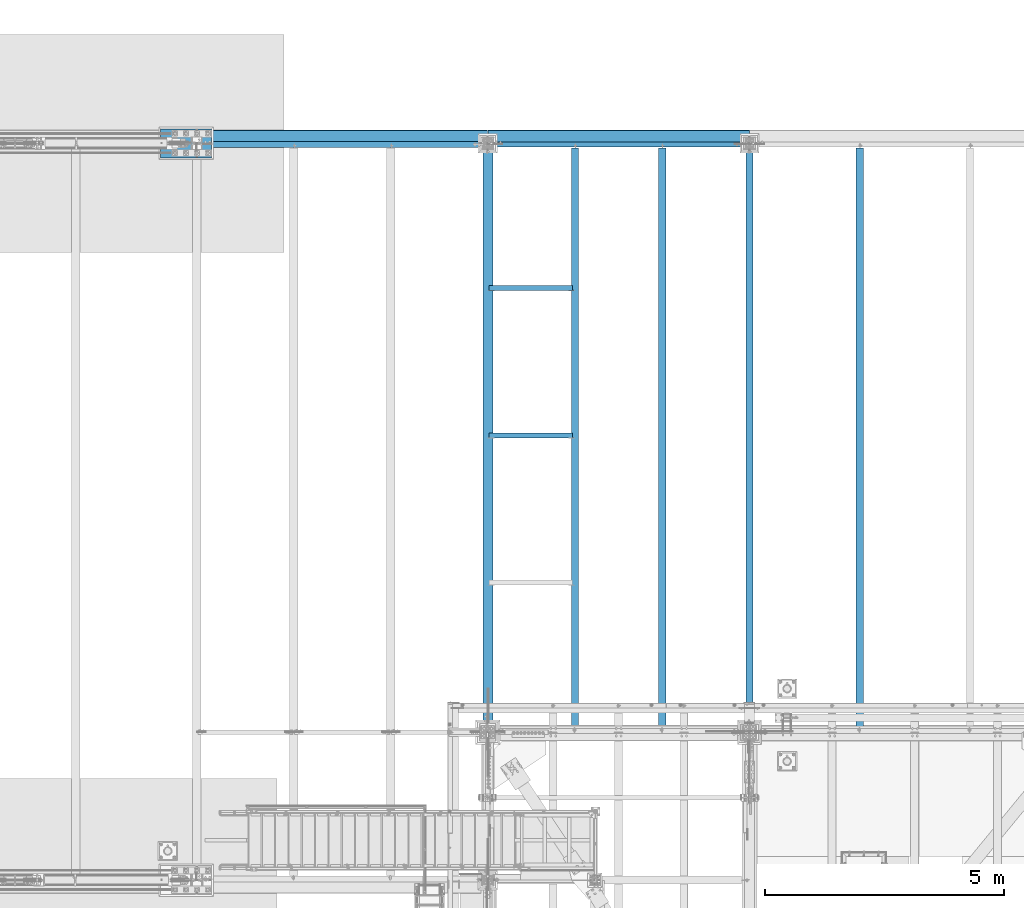
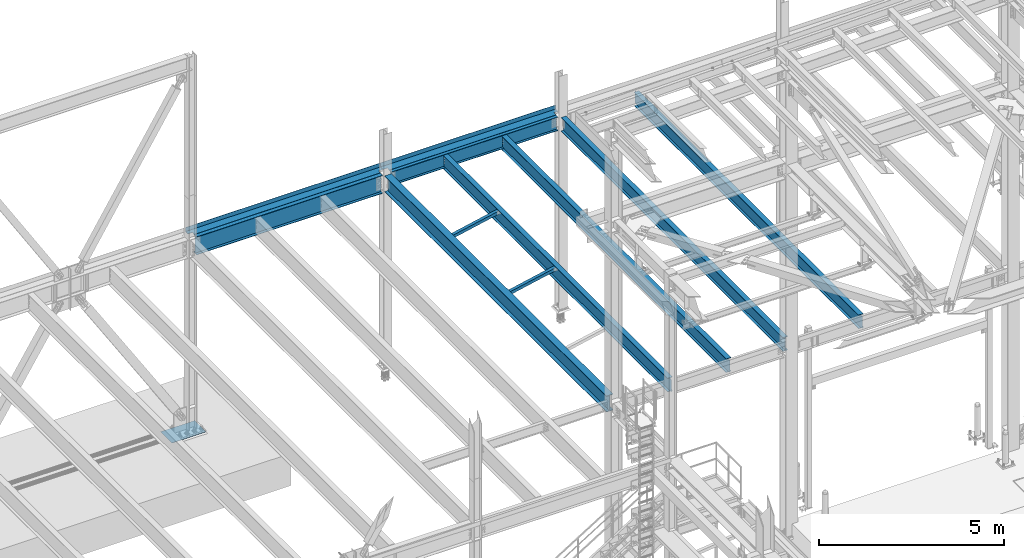
# One storey, part 1934 of 3843: 12 beams, 10 elements without a shape of their own.
"""IFC2X3 building model written with IfcOpenShell, lengths in millimetres."""

from ifc_helpers import new_model, si_unit, frame, origin_with_axes, place, context, subcontext, project, spatial, faceted_brep, material, type_object, element, aggregate, save


model = new_model("IFC2X3")

# Units and contexts
model_context = context("Model", 3, precision=1e-05, world=origin_with_axes())
body_context = subcontext(model_context, "Body", "Model", "MODEL_VIEW")
ifc_project = project(units=[si_unit("LENGTHUNIT", "METRE", prefix="MILLI"), si_unit("AREAUNIT", "SQUARE_METRE"), si_unit("VOLUMEUNIT", "CUBIC_METRE"), si_unit("MASSUNIT", "GRAM", prefix="KILO"), si_unit("TIMEUNIT", "SECOND"), si_unit("PLANEANGLEUNIT", "RADIAN"), si_unit("SOLIDANGLEUNIT", "STERADIAN"), si_unit("THERMODYNAMICTEMPERATUREUNIT", "DEGREE_CELSIUS"), si_unit("LUMINOUSINTENSITYUNIT", "LUMEN")], contexts=[model_context])

# Site, building, storey
site_placement = place(None, origin_with_axes())
site = spatial("IfcSite", under=ifc_project, at=site_placement, CompositionType="ELEMENT")
building_placement = place(site_placement, origin_with_axes())
building = spatial("IfcBuilding", under=site, at=building_placement, Name="Undefined", CompositionType="ELEMENT")
storey_placement = place(building_placement, origin_with_axes())
storey = spatial("IfcBuildingStorey", under=building, at=storey_placement, Name="Undefined", CompositionType="ELEMENT", Elevation=0.0)

# Assembly, beam
assembly_1_placement = place(storey_placement, origin_with_axes())
assembly_1 = element("IfcElementAssembly", 1, at=assembly_1_placement, inside=storey, Name="ANGLE", AssemblyPlace="NOTDEFINED", PredefinedType="RIGID_FRAME")
ifc_material_1 = material(Name="STEEL/A572-50")
beam_type_1 = type_object("IfcBeamType", Name="L4X4X3/8", PredefinedType="NOTDEFINED")
beam_1_placement = place(assembly_1_placement, frame((38364.4744366695, 101523.8, 36361.1915884738), z_axis=(0.0, 1.0, 0.0), x_axis=(-0.978512037964654, 0.0, -0.206189697992554)))
beam_1 = element("IfcBeam", 2, at=beam_1_placement, type_object=beam_type_1, material=ifc_material_1, Name="ANGLE", ObjectType="L4X4X3/8", context=body_context, shape_type="Brep", body=[
    faceted_brep([(0.0, 50.8000000000029, -50.8000000000029), (0.0, 50.8000000000029, 50.8000000000029), (1786.21921067611, 50.7999999987005, 50.8000000000029), (1786.21921067611, 50.7999999987005, -50.8000000000029), (0.0, 41.2750000000015, 50.8000000000029), (1786.2192106761, 41.27499999867, 50.8000000000029), (0.0, 41.2749999999942, -41.2750000000015), (1786.2192106761, 41.27499999867, -41.2749999999942), (0.0, -50.8000000000029, -41.2750000000015), (1786.21921067603, -50.8000000016073, -41.2749999999942), (0.0, -50.8000000000029, -50.8000000000029), (1786.21921067603, -50.8000000016073, -50.8000000000029)], [[[0, 1, 2, 3]], [[1, 4, 5, 2]], [[4, 6, 7, 5]], [[6, 8, 9, 7]], [[8, 10, 11, 9]], [[10, 0, 3, 11]], [[5, 7, 9, 11, 3, 2]], [[10, 8, 6, 4, 1, 0]]]),
])
aggregate(assembly_1, [beam_1])

assembly_2_placement = place(storey_placement, origin_with_axes())
assembly_2 = element("IfcElementAssembly", 3, at=assembly_2_placement, inside=storey, Name="ANGLE", AssemblyPlace="NOTDEFINED", PredefinedType="RIGID_FRAME")
beam_2_placement = place(assembly_2_placement, frame((38364.4744366695, 98437.7, 36361.1915884738), z_axis=(0.0, 1.0, 0.0), x_axis=(-0.978512037964654, 0.0, -0.206189697992554)))
beam_2 = element("IfcBeam", 4, at=beam_2_placement, type_object=beam_type_1, material=ifc_material_1, Name="ANGLE", ObjectType="L4X4X3/8", context=body_context, shape_type="Brep", body=[
    faceted_brep([(0.0, 50.8000000000029, -50.8000000000029), (0.0, 50.8000000000029, 50.8000000000029), (1786.21921067611, 50.7999999987005, 50.8000000000029), (1786.21921067611, 50.7999999987005, -50.8000000000029), (0.0, 41.2750000000015, 50.8000000000029), (1786.2192106761, 41.27499999867, 50.8000000000029), (0.0, 41.2749999999942, -41.2750000000015), (1786.2192106761, 41.27499999867, -41.2749999999942), (0.0, -50.8000000000029, -41.2750000000015), (1786.21921067603, -50.8000000016073, -41.2749999999942), (0.0, -50.8000000000029, -50.8000000000029), (1786.21921067603, -50.8000000016073, -50.8000000000029)], [[[0, 1, 2, 3]], [[1, 4, 5, 2]], [[4, 6, 7, 5]], [[6, 8, 9, 7]], [[8, 10, 11, 9]], [[10, 0, 3, 11]], [[5, 7, 9, 11, 3, 2]], [[10, 8, 6, 4, 1, 0]]]),
])
aggregate(assembly_2, [beam_2])

assembly_3_placement = place(storey_placement, origin_with_axes())
assembly_3 = element("IfcElementAssembly", 5, at=assembly_3_placement, inside=storey, Name="BEAM", AssemblyPlace="NOTDEFINED", PredefinedType="RIGID_FRAME")
ifc_material_2 = material(Name="STEEL/A36")
beam_type_2 = type_object("IfcBeamType", PredefinedType="NOTDEFINED")
beam_3_placement = place(assembly_3_placement, frame((39319.2, 104584.5, 36439.475), z_axis=(-1.0, 0.0, 0.0), x_axis=(0.0, 1.0, 0.0)))
beam_3 = element("IfcBeam", 6, at=beam_3_placement, type_object=beam_type_2, material=ifc_material_2, Name="BENT_PLATE", context=body_context, shape_type="Brep", body=[
    faceted_brep([(114.299996948175, -3.17499999999563, 2603.50000000001), (114.299996948175, 3.17500000000291, 2603.50000000001), (0.0, 3.17500000000291, 2603.50000000001), (0.0, -3.17500000000291, 2603.50000000001), (114.299996948175, -3.17499999999563, 2740.02499389649), (114.299996948175, 3.17500000000291, 2740.025), (0.0, -3.17500000000291, -2603.50000610351), (0.0, 3.17500000000291, -2603.50000610351), (114.299996948175, 3.17500000000291, -2603.50000610351), (114.299996948175, -3.17499999999563, -2603.50000610351), (114.299996948175, 3.17500000000291, -2740.025), (114.299996948175, -3.17499999999563, -2740.025), (253.999999999913, 3.17500000001019, -2740.025), (253.999999999956, -136.524996948319, -2740.025), (247.649999999951, -136.524996948319, -2740.025), (247.649999999907, -3.17499999999563, -2740.025), (253.999999999913, 3.17500000001019, 2740.025), (253.999999999956, -136.524996948319, 2740.025), (247.649999999951, -136.524996948319, 2740.025), (247.649999999907, -3.17499999999563, 2740.025)], [[[0, 1, 2, 3]], [[4, 5, 1, 0]], [[6, 7, 8, 9]], [[9, 8, 10, 11]], [[12, 13, 14, 15, 11, 10]], [[12, 16, 17, 13]], [[18, 14, 13, 17]], [[19, 15, 14, 18]], [[3, 6, 9, 11, 15, 19, 4, 0]], [[7, 6, 3, 2]], [[16, 12, 10, 8, 7, 2, 1, 5]], [[19, 18, 17, 16, 5, 4]]]),
])

assembly_4_placement = place(storey_placement, origin_with_axes())
assembly_4 = element("IfcElementAssembly", 7, at=assembly_4_placement, inside=storey, Name="BEAM", AssemblyPlace="NOTDEFINED", PredefinedType="RIGID_FRAME")
beam_type_3 = type_object("IfcBeamType", PredefinedType="NOTDEFINED")
beam_4_placement = place(assembly_4_placement, frame((33528.0, 104597.2, 36439.475), z_axis=(-1.0, 0.0, 0.0), x_axis=(0.0, 1.0, 0.0)))
beam_4 = element("IfcBeam", 8, at=beam_4_placement, type_object=beam_type_3, material=ifc_material_2, Name="BENT_PLATE", context=body_context, shape_type="Brep", body=[
    faceted_brep([(103.187496948172, -3.17499999999563, 2905.12500000001), (103.187496948172, 3.17500000000291, 2905.12500000001), (0.0, 3.17500000000291, 2905.12500000001), (0.0, -3.17500000000291, 2905.12500000001), (103.187496948172, -3.17499999999563, 3044.82500000001), (103.187496948172, 3.17500000000291, 3044.825), (0.0, -3.17500000000291, -2908.30000610351), (0.0, 3.17500000000291, -2908.30000610351), (101.599996948178, 3.17500000000291, -2908.30000610351), (101.599996948178, -3.17499999999563, -2908.30000610351), (101.599996948178, 3.17500000000291, -3044.825), (101.599996948178, -3.17499999999563, -3044.825), (241.300003051671, 3.17500000001019, -3044.825), (241.300003051714, -136.524996948319, -3044.825), (234.950003051708, -136.524996948319, -3044.825), (234.950003051665, -3.17499999999563, -3044.825), (241.300003051671, 3.17500000001019, 3044.825), (241.300003051714, -136.524996948319, 3044.825), (234.950003051708, -136.524996948319, 3044.825), (234.950003051665, -3.17499999999563, 3044.825)], [[[0, 1, 2, 3]], [[4, 5, 1, 0]], [[6, 7, 8, 9]], [[9, 8, 10, 11]], [[12, 13, 14, 15, 11, 10]], [[12, 16, 17, 13]], [[18, 14, 13, 17]], [[19, 15, 14, 18]], [[3, 6, 9, 11, 15, 19, 4, 0]], [[7, 6, 3, 2]], [[16, 12, 10, 8, 7, 2, 1, 5]], [[19, 18, 17, 16, 5, 4]]]),
])

assembly_5_placement = place(storey_placement, origin_with_axes())
assembly_5 = element("IfcElementAssembly", 9, at=assembly_5_placement, inside=storey, Name="BEAM", AssemblyPlace="NOTDEFINED", PredefinedType="RIGID_FRAME")
ifc_material_3 = material(Name="STEEL/A992")
beam_type_4 = type_object("IfcBeamType", Name="W18X40", PredefinedType="NOTDEFINED")
beam_5_placement = place(assembly_5_placement, frame((44373.8, 92214.7, 36209.2875), z_axis=(0.0, 0.0, 1.0), x_axis=(0.0, 1.0, 0.0)))
beam_5 = element("IfcBeam", 10, at=beam_5_placement, type_object=beam_type_4, material=ifc_material_3, Name="BEAM", ObjectType="W18X40", context=body_context, shape_type="Brep", body=[
    faceted_brep([(16.6687499999971, -3.96875, -201.612500000003), (16.6687499999971, 3.96875, -201.612500000003), (80.1687501907145, 3.96875, -201.612500000003), (80.1687501907145, -3.96875, -201.612500000003), (85.0288297087536, 3.96875, -202.579229922594), (85.0288297087536, -3.96875, -202.579229922594), (89.1490061769146, 3.96875, -205.332243823068), (89.1490061769146, -3.96875, -205.332243823068), (91.9020200773957, 3.96875, -209.452420291222), (91.9020200773957, -3.96875, -209.452420291222), (92.8687499999796, 3.96875, -214.3125), (92.8687499999796, -3.96875, -214.3125), (92.8687499999796, -76.1999999999971, -214.312499809268), (92.8687499999796, 76.1999999999971, -214.3125), (92.8687499999796, 76.1999999999971, -227.012499999997), (92.8687499999796, -76.1999999999971, -227.012499809534), (12251.53125, -76.1999999999971, -227.012499999997), (12251.53125, 76.1999999999971, -227.012499999997), (12251.53125, 76.1999999999971, -214.57249980927), (12251.53125, -76.1999999999971, -214.57249980927), (12251.53125, 76.1999999999971, 214.3125), (12251.53125, 3.96875, 214.3125), (92.8687499999942, 3.96875, 214.3125), (92.8687499999942, 76.1999999999971, 214.3125), (80.168750190729, -3.96875, 201.612499999996), (80.168750190729, 3.96875, 201.612499999996), (16.6687499999971, 3.96875, 201.612499999996), (16.6687499999971, -3.96875, 201.612499999996), (85.0288297087682, -3.96875, 202.579229922587), (85.0288297087682, 3.96875, 202.579229922587), (89.1490061769291, -3.96875, 205.332243823061), (89.1490061769291, 3.96875, 205.332243823061), (91.9020200774103, -3.96875, 209.452420291214), (91.9020200774103, 3.96875, 209.452420291214), (92.8687499999942, -3.96875, 214.3125), (12251.53125, -76.1999999999971, 227.012499999997), (12251.53125, 76.1999999999971, 227.012499999997), (92.8687499999942, 76.1999999999971, 227.012499999997), (92.8687499999942, -76.1999999999971, 227.01249980952), (12251.53125, -76.1999999999971, 214.3125), (92.8687499999942, -76.1999999999971, 214.3125), (12251.53125, -3.96875, 214.3125), (12251.53125, -3.96875, 214.052501487728), (12251.53125, 3.96875, 214.052501487728), (12252.4979799226, -3.96875, 209.192421969681), (12252.4979799226, 3.96875, 209.192421969681), (12255.2509938231, -3.96875, 205.072245501528), (12255.2509938231, 3.96875, 205.072245501528), (12259.3711702912, -3.96875, 202.319231601054), (12259.3711702912, 3.96875, 202.319231601054), (12264.2312498093, -3.96875, 201.352501678462), (12264.2312498093, 3.96875, 201.352501678462), (12327.73125, -3.96875, 201.352499999994), (12327.73125, 3.96875, 201.352499999994), (12327.73125, -3.96875, -201.872500000005), (12327.73125, 3.96875, -201.872500000005), (12264.2312498093, -3.96875, -201.872500000005), (12264.2312498093, 3.96875, -201.872500000005), (12259.3711702912, -3.96875, -202.839229922596), (12259.3711702912, 3.96875, -202.839229922596), (12255.2509938231, -3.96875, -205.59224382307), (12255.2509938231, 3.96875, -205.59224382307), (12252.4979799226, -3.96875, -209.712420291224), (12252.4979799226, 3.96875, -209.712420291224), (12251.5829671776, -3.96875, -214.3125), (12251.5829671776, -76.1999999999971, -214.3125), (12251.5829671776, 76.1999999999971, -214.3125), (12251.5829671776, 3.96875, -214.3125), (16.6687499999971, 3.96875, -117.887499999997), (16.6687499999971, 3.96875, 188.912499999999)], [[[0, 1, 2, 3]], [[3, 2, 4, 5]], [[5, 4, 6, 7]], [[7, 6, 8, 9]], [[9, 8, 10, 11]], [[12, 11, 10, 13, 14, 15]], [[16, 17, 18, 19]], [[20, 21, 22, 23]], [[24, 25, 26, 27]], [[28, 29, 25, 24]], [[30, 31, 29, 28]], [[32, 33, 31, 30]], [[34, 22, 33, 32]], [[35, 36, 37, 38]], [[39, 35, 38, 40]], [[41, 39, 40, 34]], [[38, 37, 23, 22, 34, 40]], [[36, 20, 23, 37]], [[35, 39, 41, 42, 43, 21, 20, 36]], [[44, 45, 43, 42]], [[46, 47, 45, 44]], [[48, 49, 47, 46]], [[50, 51, 49, 48]], [[52, 53, 51, 50]], [[53, 52, 54, 55]], [[54, 56, 57, 55]], [[58, 59, 57, 56]], [[60, 61, 59, 58]], [[62, 63, 61, 60]], [[64, 65, 19, 18, 66, 67, 63, 62]], [[16, 19, 65, 12, 15]], [[17, 16, 15, 14]], [[66, 18, 17, 14, 13]], [[67, 66, 13, 10]], [[6, 4, 2, 1, 68, 69, 26, 25, 29, 31, 33, 22, 21, 43, 45, 47, 49, 51, 53, 55, 57, 59, 61, 63, 67, 10, 8]], [[27, 26, 69, 68, 1, 0]], [[64, 62, 60, 58, 56, 54, 52, 50, 48, 46, 44, 42, 41, 34, 32, 30, 28, 24, 27, 0, 3, 5, 7, 9, 11]], [[65, 64, 11, 12]]]),
])
aggregate(assembly_5, [beam_5])

assembly_6_placement = place(storey_placement, origin_with_axes())
assembly_6 = element("IfcElementAssembly", 11, at=assembly_6_placement, inside=storey, Name="BEAM", AssemblyPlace="NOTDEFINED", PredefinedType="RIGID_FRAME")
beam_6_placement = place(assembly_6_placement, frame((38404.8, 92214.7, 36209.2875), z_axis=(0.0, 0.0, 1.0), x_axis=(0.0, 1.0, 0.0)))
beam_6 = element("IfcBeam", 12, at=beam_6_placement, type_object=beam_type_4, material=ifc_material_3, Name="BEAM", ObjectType="W18X40", context=body_context, shape_type="Brep", body=[
    faceted_brep([(16.6687499999971, -3.96875, -201.612500000003), (16.6687499999971, 3.96875, -201.612500000003), (80.1687501907145, 3.96875, -201.612500000003), (80.1687501907145, -3.96875, -201.612500000003), (85.0288297087536, 3.96875, -202.579229922594), (85.0288297087536, -3.96875, -202.579229922594), (89.1490061769146, 3.96875, -205.332243823068), (89.1490061769146, -3.96875, -205.332243823068), (91.9020200773957, 3.96875, -209.452420291222), (91.9020200773957, -3.96875, -209.452420291222), (92.8687499999796, 3.96875, -214.3125), (92.8687499999796, -3.96875, -214.3125), (92.8687499999796, -76.1999999999971, -214.312499809268), (92.8687499999796, 76.1999999999971, -214.3125), (92.8687499999796, 76.1999999999971, -227.012499999997), (92.8687499999796, -76.1999999999971, -227.012499809534), (12251.53125, -76.1999999999971, -227.012499999997), (12251.53125, 76.1999999999971, -227.012499999997), (12251.53125, 76.1999999999971, -214.57249980927), (12251.53125, -76.1999999999971, -214.57249980927), (12251.53125, 76.1999999999971, 214.3125), (12251.53125, 3.96875, 214.3125), (92.8687499999942, 3.96875, 214.3125), (92.8687499999942, 76.1999999999971, 214.3125), (80.168750190729, -3.96875, 201.612499999996), (80.168750190729, 3.96875, 201.612499999996), (16.6687499999971, 3.96875, 201.612499999996), (16.6687499999971, -3.96875, 201.612499999996), (85.0288297087682, -3.96875, 202.579229922587), (85.0288297087682, 3.96875, 202.579229922587), (89.1490061769291, -3.96875, 205.332243823061), (89.1490061769291, 3.96875, 205.332243823061), (91.9020200774103, -3.96875, 209.452420291214), (91.9020200774103, 3.96875, 209.452420291214), (92.8687499999942, -3.96875, 214.3125), (12251.53125, -76.1999999999971, 227.012499999997), (12251.53125, 76.1999999999971, 227.012499999997), (92.8687499999942, 76.1999999999971, 227.012499999997), (92.8687499999942, -76.1999999999971, 227.01249980952), (12251.53125, -76.1999999999971, 214.3125), (92.8687499999942, -76.1999999999971, 214.3125), (12251.53125, -3.96875, 214.3125), (12251.53125, -3.96875, 214.052501487728), (12251.53125, 3.96875, 214.052501487728), (12252.4979799226, -3.96875, 209.192421969681), (12252.4979799226, 3.96875, 209.192421969681), (12255.2509938231, -3.96875, 205.072245501528), (12255.2509938231, 3.96875, 205.072245501528), (12259.3711702912, -3.96875, 202.319231601054), (12259.3711702912, 3.96875, 202.319231601054), (12264.2312498093, -3.96875, 201.352501678462), (12264.2312498093, 3.96875, 201.352501678462), (12327.73125, -3.96875, 201.352499999994), (12327.73125, 3.96875, 201.352499999994), (12327.73125, -3.96875, -201.872500000005), (12327.73125, 3.96875, -201.872500000005), (12264.2312498093, -3.96875, -201.872500000005), (12264.2312498093, 3.96875, -201.872500000005), (12259.3711702912, -3.96875, -202.839229922596), (12259.3711702912, 3.96875, -202.839229922596), (12255.2509938231, -3.96875, -205.59224382307), (12255.2509938231, 3.96875, -205.59224382307), (12252.4979799226, -3.96875, -209.712420291224), (12252.4979799226, 3.96875, -209.712420291224), (12251.5829671776, -3.96875, -214.3125), (12251.5829671776, -76.1999999999971, -214.3125), (12251.5829671776, 76.1999999999971, -214.3125), (12251.5829671776, 3.96875, -214.3125), (16.6687499999971, 3.96875, -117.887499999997), (16.6687499999971, 3.96875, 188.912499999999)], [[[0, 1, 2, 3]], [[3, 2, 4, 5]], [[5, 4, 6, 7]], [[7, 6, 8, 9]], [[9, 8, 10, 11]], [[12, 11, 10, 13, 14, 15]], [[16, 17, 18, 19]], [[20, 21, 22, 23]], [[24, 25, 26, 27]], [[28, 29, 25, 24]], [[30, 31, 29, 28]], [[32, 33, 31, 30]], [[34, 22, 33, 32]], [[35, 36, 37, 38]], [[39, 35, 38, 40]], [[41, 39, 40, 34]], [[38, 37, 23, 22, 34, 40]], [[36, 20, 23, 37]], [[35, 39, 41, 42, 43, 21, 20, 36]], [[44, 45, 43, 42]], [[46, 47, 45, 44]], [[48, 49, 47, 46]], [[50, 51, 49, 48]], [[52, 53, 51, 50]], [[53, 52, 54, 55]], [[54, 56, 57, 55]], [[58, 59, 57, 56]], [[60, 61, 59, 58]], [[62, 63, 61, 60]], [[64, 65, 19, 18, 66, 67, 63, 62]], [[16, 19, 65, 12, 15]], [[17, 16, 15, 14]], [[66, 18, 17, 14, 13]], [[67, 66, 13, 10]], [[6, 4, 2, 1, 68, 69, 26, 25, 29, 31, 33, 22, 21, 43, 45, 47, 49, 51, 53, 55, 57, 59, 61, 63, 67, 10, 8]], [[27, 26, 69, 68, 1, 0]], [[64, 62, 60, 58, 56, 54, 52, 50, 48, 46, 44, 42, 41, 34, 32, 30, 28, 24, 27, 0, 3, 5, 7, 9, 11]], [[65, 64, 11, 12]]]),
])
aggregate(assembly_6, [beam_6])

assembly_7_placement = place(storey_placement, origin_with_axes())
assembly_7 = element("IfcElementAssembly", 13, at=assembly_7_placement, inside=storey, Name="BEAM", AssemblyPlace="NOTDEFINED", PredefinedType="RIGID_FRAME")
beam_7_placement = place(assembly_7_placement, frame((40233.6, 92214.7, 36209.2875), z_axis=(0.0, 0.0, 1.0), x_axis=(0.0, 1.0, 0.0)))
beam_7 = element("IfcBeam", 14, at=beam_7_placement, type_object=beam_type_4, material=ifc_material_3, Name="BEAM", ObjectType="W18X40", context=body_context, shape_type="Brep", body=[
    faceted_brep([(16.6687499999971, -3.96875, -201.612500000003), (16.6687499999971, 3.96875, -201.612500000003), (80.1687501907145, 3.96875, -201.612500000003), (80.1687501907145, -3.96875, -201.612500000003), (85.0288297087536, 3.96875, -202.579229922594), (85.0288297087536, -3.96875, -202.579229922594), (89.1490061769146, 3.96875, -205.332243823068), (89.1490061769146, -3.96875, -205.332243823068), (91.9020200773957, 3.96875, -209.452420291222), (91.9020200773957, -3.96875, -209.452420291222), (92.8687499999796, 3.96875, -214.3125), (92.8687499999796, -3.96875, -214.3125), (92.8687499999796, -76.1999999999971, -214.312499809268), (92.8687499999796, 76.1999999999971, -214.3125), (92.8687499999796, 76.1999999999971, -227.012499999997), (92.8687499999796, -76.1999999999971, -227.012499809534), (12251.53125, -76.1999999999971, -227.012499999997), (12251.53125, 76.1999999999971, -227.012499999997), (12251.53125, 76.1999999999971, -214.57249980927), (12251.53125, -76.1999999999971, -214.57249980927), (12251.53125, 76.1999999999971, 214.3125), (12251.53125, 3.96875, 214.3125), (92.8687499999942, 3.96875, 214.3125), (92.8687499999942, 76.1999999999971, 214.3125), (80.168750190729, -3.96875, 201.612499999996), (80.168750190729, 3.96875, 201.612499999996), (16.6687499999971, 3.96875, 201.612499999996), (16.6687499999971, -3.96875, 201.612499999996), (85.0288297087682, -3.96875, 202.579229922587), (85.0288297087682, 3.96875, 202.579229922587), (89.1490061769291, -3.96875, 205.332243823061), (89.1490061769291, 3.96875, 205.332243823061), (91.9020200774103, -3.96875, 209.452420291214), (91.9020200774103, 3.96875, 209.452420291214), (92.8687499999942, -3.96875, 214.3125), (12251.53125, -76.1999999999971, 227.012499999997), (12251.53125, 76.1999999999971, 227.012499999997), (92.8687499999942, 76.1999999999971, 227.012499999997), (92.8687499999942, -76.1999999999971, 227.01249980952), (12251.53125, -76.1999999999971, 214.3125), (92.8687499999942, -76.1999999999971, 214.3125), (12251.53125, -3.96875, 214.3125), (12251.53125, -3.96875, 214.052501487728), (12251.53125, 3.96875, 214.052501487728), (12252.4979799226, -3.96875, 209.192421969681), (12252.4979799226, 3.96875, 209.192421969681), (12255.2509938231, -3.96875, 205.072245501528), (12255.2509938231, 3.96875, 205.072245501528), (12259.3711702912, -3.96875, 202.319231601054), (12259.3711702912, 3.96875, 202.319231601054), (12264.2312498093, -3.96875, 201.352501678462), (12264.2312498093, 3.96875, 201.352501678462), (12327.73125, -3.96875, 201.352499999994), (12327.73125, 3.96875, 201.352499999994), (12327.73125, -3.96875, -201.872500000005), (12327.73125, 3.96875, -201.872500000005), (12264.2312498093, -3.96875, -201.872500000005), (12264.2312498093, 3.96875, -201.872500000005), (12259.3711702912, -3.96875, -202.839229922596), (12259.3711702912, 3.96875, -202.839229922596), (12255.2509938231, -3.96875, -205.59224382307), (12255.2509938231, 3.96875, -205.59224382307), (12252.4979799226, -3.96875, -209.712420291224), (12252.4979799226, 3.96875, -209.712420291224), (12251.5829671776, -3.96875, -214.3125), (12251.5829671776, -76.1999999999971, -214.3125), (12251.5829671776, 76.1999999999971, -214.3125), (12251.5829671776, 3.96875, -214.3125), (16.6687499999971, 3.96875, -117.887499999997), (16.6687499999971, 3.96875, 188.912499999999)], [[[0, 1, 2, 3]], [[3, 2, 4, 5]], [[5, 4, 6, 7]], [[7, 6, 8, 9]], [[9, 8, 10, 11]], [[12, 11, 10, 13, 14, 15]], [[16, 17, 18, 19]], [[20, 21, 22, 23]], [[24, 25, 26, 27]], [[28, 29, 25, 24]], [[30, 31, 29, 28]], [[32, 33, 31, 30]], [[34, 22, 33, 32]], [[35, 36, 37, 38]], [[39, 35, 38, 40]], [[41, 39, 40, 34]], [[38, 37, 23, 22, 34, 40]], [[36, 20, 23, 37]], [[35, 39, 41, 42, 43, 21, 20, 36]], [[44, 45, 43, 42]], [[46, 47, 45, 44]], [[48, 49, 47, 46]], [[50, 51, 49, 48]], [[52, 53, 51, 50]], [[53, 52, 54, 55]], [[54, 56, 57, 55]], [[58, 59, 57, 56]], [[60, 61, 59, 58]], [[62, 63, 61, 60]], [[64, 65, 19, 18, 66, 67, 63, 62]], [[16, 19, 65, 12, 15]], [[17, 16, 15, 14]], [[66, 18, 17, 14, 13]], [[67, 66, 13, 10]], [[6, 4, 2, 1, 68, 69, 26, 25, 29, 31, 33, 22, 21, 43, 45, 47, 49, 51, 53, 55, 57, 59, 61, 63, 67, 10, 8]], [[27, 26, 69, 68, 1, 0]], [[64, 62, 60, 58, 56, 54, 52, 50, 48, 46, 44, 42, 41, 34, 32, 30, 28, 24, 27, 0, 3, 5, 7, 9, 11]], [[65, 64, 11, 12]]]),
])
aggregate(assembly_7, [beam_7])

assembly_8_placement = place(storey_placement, origin_with_axes())
assembly_8 = element("IfcElementAssembly", 15, at=assembly_8_placement, inside=storey, Name="BEAM", AssemblyPlace="NOTDEFINED", PredefinedType="RIGID_FRAME")
beam_8_placement = place(assembly_8_placement, frame((42062.4, 92214.7, 36209.2875), z_axis=(0.0, 0.0, 1.0), x_axis=(0.0, 1.0, 0.0)))
beam_8 = element("IfcBeam", 16, at=beam_8_placement, type_object=beam_type_4, material=ifc_material_3, Name="BEAM", ObjectType="W18X40", context=body_context, shape_type="Brep", body=[
    faceted_brep([(190.5, -76.1999999999971, -227.012499999997), (190.5, 76.1999999999971, -227.012499999997), (12204.7, 76.1999999999998, -227.012499999997), (12204.7, -76.1999999999998, -227.012499999997), (190.5, -76.1999999999971, -214.3125), (190.5, -3.96875, -214.3125), (190.5, -3.96875, 214.3125), (190.5, -76.1999999999971, 214.3125), (190.5, -76.1999999999971, 227.012499999997), (190.5, 76.1999999999971, 227.012499999997), (190.5, 76.1999999999971, 214.3125), (190.5, 3.96875, 214.3125), (190.5, 3.96875, -214.3125), (190.5, 76.1999999999971, -214.3125), (12204.7, -76.1999999999998, -214.3125), (12204.7, -3.96875, -214.3125), (12204.7, -3.96875, 214.3125), (12204.7, -76.1999999999998, 214.3125), (12204.7, -76.1999999999998, 227.012499999997), (12204.7, 76.1999999999998, 227.012499999997), (12204.7, 76.1999999999998, 214.3125), (12204.7, 3.96875, 214.3125), (12204.7, 3.96875, -214.3125), (12204.7, 76.1999999999998, -214.3125)], [[[0, 1, 2, 3]], [[0, 4, 5, 6, 7, 8, 9, 10, 11, 12, 13, 1]], [[5, 4, 14, 15]], [[6, 5, 15, 16]], [[7, 6, 16, 17]], [[8, 7, 17, 18]], [[9, 8, 18, 19]], [[10, 9, 19, 20]], [[11, 10, 20, 21]], [[12, 11, 21, 22]], [[13, 12, 22, 23]], [[1, 13, 23, 2]], [[22, 21, 20, 19, 18, 17, 16, 15, 14, 3, 2, 23]], [[4, 0, 3, 14]]]),
])
aggregate(assembly_8, [beam_8])

# Beam
beam_9_placement = place(assembly_3_placement, frame((36576.0, 104559.1, 36209.2875), z_axis=(0.0, 0.0, 1.0), x_axis=(1.0, 0.0, 0.0)))
beam_9 = element("IfcBeam", 17, at=beam_9_placement, type_object=beam_type_4, material=ifc_material_3, Name="BEAM", ObjectType="W18X40", context=body_context, shape_type="Brep", body=[
    faceted_brep([(139.700000000012, -76.1999999999998, -227.012499999997), (139.700000000012, 76.1999999999998, -227.012499999997), (5346.7, 76.1999999999971, -227.012499999997), (5346.7, -76.1999999999971, -227.012499999997), (139.700000000012, -76.1999999999998, -214.3125), (139.700000000012, -3.96875, -214.3125), (139.699999999997, -3.96875, -129.327499999999), (139.699999999997, -3.96875, 189.652499999997), (139.700000000012, -3.96875, 214.3125), (139.700000000012, -76.1999999999998, 214.3125), (139.700000000012, -76.1999999999998, 227.012499999997), (139.700000000012, 76.1999999999998, 227.012499999997), (139.700000000012, 76.1999999999998, 214.3125), (139.700000000012, 3.96875, 214.3125), (139.700000000012, 3.96875, -214.3125), (139.700000000012, 76.1999999999998, -214.3125), (5346.7, -76.1999999999971, -214.3125), (5346.7, -3.96875, -214.3125), (5346.7, -3.96875, -129.327499999999), (5346.7, -3.96875, 189.652499999997), (5346.7, -3.96875, 214.3125), (5346.7, -76.1999999999971, 214.3125), (5346.7, -76.1999999999971, 227.012499999997), (5346.7, 76.1999999999971, 227.012499999997), (5346.7, 76.1999999999971, 214.3125), (5346.7, 3.96875, 214.3125), (5346.7, 3.96875, -214.3125), (5346.7, 76.1999999999971, -214.3125)], [[[0, 1, 2, 3]], [[0, 4, 5, 6, 7, 8, 9, 10, 11, 12, 13, 14, 15, 1]], [[5, 4, 16, 17]], [[8, 7, 6, 5, 17, 18, 19, 20]], [[9, 8, 20, 21]], [[10, 9, 21, 22]], [[11, 10, 22, 23]], [[12, 11, 23, 24]], [[13, 12, 24, 25]], [[14, 13, 25, 26]], [[15, 14, 26, 27]], [[1, 15, 27, 2]], [[26, 25, 24, 23, 22, 21, 20, 19, 18, 17, 16, 3, 2, 27]], [[4, 0, 3, 16]]]),
])

aggregate(assembly_3, [beam_3, beam_9])

beam_type_5 = type_object("IfcBeamType", Name="W24X55", PredefinedType="NOTDEFINED")
beam_10_placement = place(assembly_4_placement, frame((30480.0, 104559.1, 36136.2625), z_axis=(0.0, 0.0, 1.0), x_axis=(1.0, 0.0, 0.0)))
beam_10 = element("IfcBeam", 18, at=beam_10_placement, type_object=beam_type_5, material=ifc_material_3, Name="BEAM", ObjectType="W24X55", context=body_context, shape_type="Brep", body=[
    faceted_brep([(142.875, -88.8999999999942, -300.037499999999), (142.875, 88.8999999999942, -300.037499999999), (5956.3, 88.8999999999942, -300.037499999999), (5956.3, -88.8999999999942, -300.037499999999), (142.875, -88.8999999999942, -287.337500000001), (142.875, -4.76249999999709, -287.337500000001), (142.875, -4.76249999999709, 287.337500000001), (142.875, -88.8999999999942, 287.337500000001), (142.875, -88.8999999999942, 300.037499999999), (142.875, 88.8999999999942, 300.037499999999), (142.875, 88.8999999999942, 287.337500000001), (142.875, 4.76249999999709, 287.337500000001), (142.875, 4.76249999999709, -287.337500000001), (142.875, 88.8999999999942, -287.337500000001), (5956.3, -88.8999999999942, -287.337500000001), (5956.3, -4.76249999999709, -287.337500000001), (5956.3, -4.76249999999709, -208.702493896482), (5956.3, -4.76249999999709, 262.677499999998), (5956.3, -4.76249999999709, 287.337500000001), (5956.3, -88.8999999999942, 287.337500000001), (5956.3, -88.8999999999942, 300.037499999999), (5956.3, 88.8999999999942, 300.037499999999), (5956.3, 88.8999999999942, 287.337500000001), (5956.3, 4.76249999999709, 287.337500000001), (5956.3, 4.76249999999709, -287.337500000001), (5956.3, 88.8999999999942, -287.337500000001)], [[[0, 1, 2, 3]], [[0, 4, 5, 6, 7, 8, 9, 10, 11, 12, 13, 1]], [[5, 4, 14, 15]], [[6, 5, 15, 16, 17, 18]], [[7, 6, 18, 19]], [[8, 7, 19, 20]], [[9, 8, 20, 21]], [[10, 9, 21, 22]], [[11, 10, 22, 23]], [[12, 11, 23, 24]], [[13, 12, 24, 25]], [[1, 13, 25, 2]], [[24, 23, 22, 21, 20, 19, 18, 17, 16, 15, 14, 3, 2, 25]], [[4, 0, 3, 14]]]),
])

aggregate(assembly_4, [beam_4, beam_10])

# Assembly, beam
assembly_9_placement = place(storey_placement, origin_with_axes())
assembly_9 = element("IfcElementAssembly", 19, at=assembly_9_placement, inside=storey, Name="BEAM", AssemblyPlace="NOTDEFINED", PredefinedType="RIGID_FRAME")
beam_type_6 = type_object("IfcBeamType", Name="W21X62", PredefinedType="NOTDEFINED")
beam_11_placement = place(assembly_9_placement, frame((36576.0, 92214.7, 36169.6), z_axis=(0.0, 0.0, 1.0), x_axis=(0.0, 1.0, 0.0)))
beam_11 = element("IfcBeam", 20, at=beam_11_placement, type_object=beam_type_6, material=ifc_material_3, Name="BEAM", ObjectType="W21X62", context=body_context, shape_type="Brep", body=[
    faceted_brep([(196.850000000035, -104.775000000001, -250.824999999997), (196.850000000035, -104.775000000001, -266.699999999997), (12204.7, -104.775000000001, -266.699999999997), (12204.7, -104.775000000001, -250.824999999997), (196.850000000035, -4.76249999999709, -250.824999999997), (12204.7, -4.76249999999709, -250.824999999997), (196.850000000035, -4.76249999999709, 250.824999999997), (12204.7, -4.76249999999709, 250.824999999997), (196.850000000035, -104.775000000001, 250.824999999997), (12204.7, -104.775000000001, 250.824999999997), (196.850000000035, -104.775000000001, 266.699999999997), (12204.7, -104.775000000001, 266.699999999997), (196.850000000035, 104.775000000001, 266.699999999997), (12204.7, 104.775000000001, 266.699999999997), (196.850000000035, 104.775000000001, 250.824999999997), (12204.7, 104.775000000001, 250.824999999997), (196.850000000035, 4.76249999999709, 250.824999999997), (12204.7, 4.76249999999709, 250.824999999997), (196.850000000035, 4.76249999999709, -250.824999999997), (12204.7, 4.76249999999709, -250.824999999997), (196.850000000035, 104.775000000001, -250.824999999997), (12204.7, 104.775000000001, -250.824999999997), (196.850000000035, 104.775000000001, -266.699999999997), (12204.7, 104.775000000001, -266.699999999997)], [[[0, 1, 2, 3]], [[4, 0, 3, 5]], [[6, 4, 5, 7]], [[8, 6, 7, 9]], [[10, 8, 9, 11]], [[12, 10, 11, 13]], [[14, 12, 13, 15]], [[16, 14, 15, 17]], [[18, 16, 17, 19]], [[20, 18, 19, 21]], [[1, 0, 4, 6, 8, 10, 12, 14, 16, 18, 20, 22]], [[1, 22, 23, 2]], [[19, 17, 15, 13, 11, 9, 7, 5, 3, 2, 23, 21]], [[22, 20, 21, 23]]]),
])
aggregate(assembly_9, [beam_11])

assembly_10_placement = place(storey_placement, origin_with_axes())
assembly_10 = element("IfcElementAssembly", 21, at=assembly_10_placement, inside=storey, Name="TEMPLATE", AssemblyPlace="NOTDEFINED", PredefinedType="RIGID_FRAME")
beam_type_7 = type_object("IfcBeamType", PredefinedType="NOTDEFINED")
beam_12_placement = place(assembly_10_placement, frame((30784.8000061035, 104559.1, 30065.6625), z_axis=(0.0, -1.0, 0.0), x_axis=(-1.0, 0.0, 0.0)))
beam_12 = element("IfcBeam", 22, at=beam_12_placement, type_object=beam_type_7, material=ifc_material_1, Name="TEMPLATE", context=body_context, shape_type="Brep", body=[
    faceted_brep([(0.0, 4.76250000000073, -304.800000000003), (0.0, 4.76250000000073, 304.800000000003), (1066.80001220703, 4.76250000000073, 304.800000000003), (1066.80001220703, 4.76250000000073, -304.800000000003), (0.0, -4.76250000000073, 304.800000000003), (1066.80001220703, -4.76250000000073, 304.800000000003), (0.0, -4.76250000000073, -304.800000000003), (1066.80001220703, -4.76250000000073, -304.800000000003)], [[[0, 1, 2, 3]], [[1, 4, 5, 2]], [[4, 6, 7, 5]], [[6, 0, 3, 7]], [[5, 7, 3, 2]], [[6, 4, 1, 0]]]),
])
aggregate(assembly_10, [beam_12])

save(model, "model.ifc")
